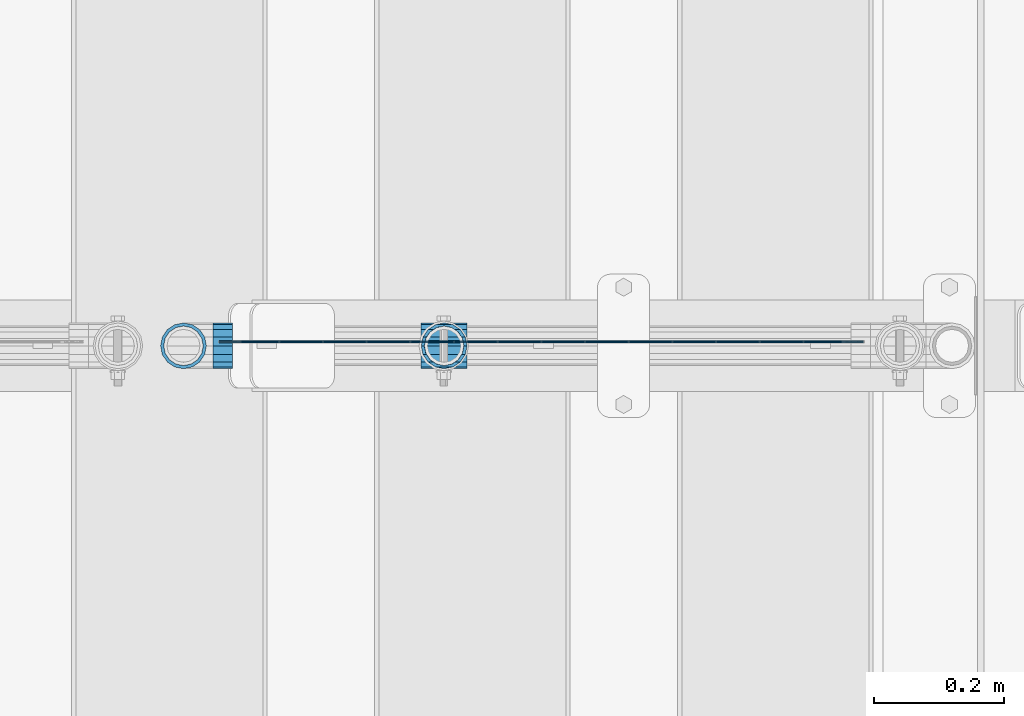
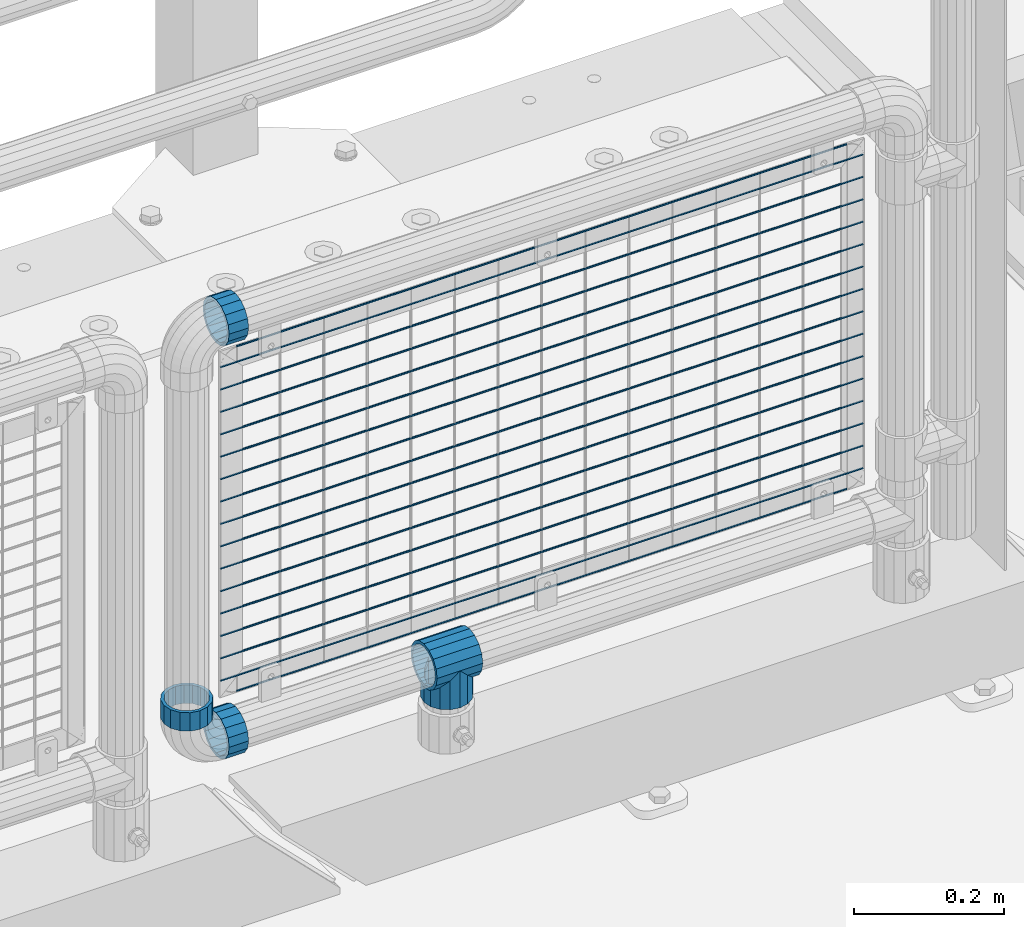
# One storey, part 135 of 208: 22 beams.
"""IFC2X3 building model written with IfcOpenShell, lengths in millimetres."""

import ifcopenshell
import ifcopenshell.guid

model = None  # the IFC model being written
_history = None  # IfcOwnerHistory: only IFC2X3 demands one
_inside = {}  # id of a spatial element -> (the spatial element, [elements in it])
_under = {}  # id of a project, library or spatial element -> (it, [spatial elements below it])
_declared = {}  # id of a project -> (the project, [libraries it declares])
_typed = {}  # id of a type object -> (the type object, [elements of that type])
_made_of = {}  # id of a material, layer set ... -> (it, [elements and type objects made of it])


def new_model(schema):
    """Start an empty IFC model of exactly this schema.

    Asked for "IFC4X3", IfcOpenShell would pick the latest addendum, in which some entities
    have other attributes; the version numbers below select the first issue.
    IFC2X3 requires an IfcOwnerHistory on every rooted entity: one is made here for all.
    """
    global model, _history
    if schema == "IFC4X3":
        model = ifcopenshell.file(schema_version=(4, 3, 0, 0))
    else:
        model = ifcopenshell.file(schema=schema)
    _inside.clear()
    _under.clear()
    _declared.clear()
    _typed.clear()
    _made_of.clear()
    _history = None
    if model.schema == "IFC2X3":
        org = make("IfcOrganization", Name="unknown")
        user = make(
            "IfcPersonAndOrganization",
            ThePerson=make("IfcPerson", FamilyName="unknown"),
            TheOrganization=org,
        )
        app = make(
            "IfcApplication",
            ApplicationDeveloper=org,
            Version="unknown",
            ApplicationFullName="unknown",
            ApplicationIdentifier="unknown",
        )
        _history = make(
            "IfcOwnerHistory",
            OwningUser=user,
            OwningApplication=app,
            ChangeAction="ADDED",
            CreationDate=0,
        )
    return model


def make(cls, **values):
    """One entity of the class cls with the attributes given. An attribute that is None is left unset."""
    return model.create_entity(
        cls, **{name: value for name, value in values.items() if value is not None}
    )


def rooted(cls, **values):
    """An entity with a GlobalId (a new one), such as an element, a storey or a relation."""
    return make(cls, GlobalId=ifcopenshell.guid.new(), OwnerHistory=_history, **values)


def si_unit(unit_type, name, prefix=None):
    """IfcSIUnit, for example si_unit("LENGTHUNIT", "METRE", prefix="MILLI")."""
    return make("IfcSIUnit", UnitType=unit_type, Prefix=prefix, Name=name)


def assignment(units):
    """IfcUnitAssignment: the units of a project."""
    return None if units is None else make("IfcUnitAssignment", Units=units)


def point(xyz):
    """IfcCartesianPoint."""
    return None if xyz is None else make("IfcCartesianPoint", Coordinates=xyz)


def direction(xyz):
    """IfcDirection."""
    return None if xyz is None else make("IfcDirection", DirectionRatios=xyz)


def frame(location, z_axis=None, x_axis=None):
    """IfcAxis2Placement3D, a coordinate frame: its origin and axes. An axis left out is left unset."""
    return make(
        "IfcAxis2Placement3D",
        Location=point(location),
        Axis=direction(z_axis),
        RefDirection=direction(x_axis),
    )


def origin_with_axes():
    """The frame at (0, 0, 0) with the z axis (0, 0, 1) and the x axis (1, 0, 0) written out."""
    return frame((0.0, 0.0, 0.0), z_axis=(0.0, 0.0, 1.0), x_axis=(1.0, 0.0, 0.0))


def place(relative_to, where):
    """IfcLocalPlacement: puts the frame where relative to a parent placement (None: the world)."""
    return make(
        "IfcLocalPlacement", PlacementRelTo=relative_to, RelativePlacement=where
    )


def context(
    kind, dimensions, precision=None, world=None, true_north=None, identifier=None
):
    """IfcGeometricRepresentationContext, for example the 3D "Model" context."""
    return make(
        "IfcGeometricRepresentationContext",
        ContextIdentifier=identifier,
        ContextType=kind,
        CoordinateSpaceDimension=dimensions,
        Precision=precision,
        WorldCoordinateSystem=world,
        TrueNorth=true_north,
    )


def subcontext(parent, identifier, kind, view, scale=None):
    """IfcGeometricRepresentationSubContext, for example "Body" below "Model"."""
    return make(
        "IfcGeometricRepresentationSubContext",
        ContextIdentifier=identifier,
        ContextType=kind,
        ParentContext=parent,
        TargetScale=scale,
        TargetView=view,
    )


def project(units=None, contexts=None):
    """IfcProject with its units and contexts."""
    return rooted(
        "IfcProject",
        Name="project",
        RepresentationContexts=contexts,
        UnitsInContext=assignment(units),
    )


def spatial(cls, under=None, at=None, **own):
    """A site, building, storey or space (cls), placed at a placement, below another one or the project."""
    s = rooted(cls, ObjectPlacement=at, **own)
    if under is not None:
        _under.setdefault(under.id(), (under, []))[1].append(s)
    return s


def faces_of(points, faces, orient=None, outer=None):
    """IfcFace entities. A face is a list of loops; a loop is a list of indices into points, from 0.

    orient and outer hold one flag for each loop. By default every Orientation is true, the
    first loop of a face is its IfcFaceOuterBound and the others are IfcFaceBound.
    """
    made = []
    for i, loops in enumerate(faces):
        bounds = []
        for j, loop in enumerate(loops):
            is_outer = j == 0 if outer is None else outer[i][j]
            bounds.append(
                make(
                    "IfcFaceOuterBound" if is_outer else "IfcFaceBound",
                    Bound=make("IfcPolyLoop", Polygon=[points[k] for k in loop]),
                    Orientation=True if orient is None else orient[i][j],
                )
            )
        made.append(make("IfcFace", Bounds=bounds))
    return made


def faceted_brep(points, faces, orient=None, outer=None, voids=None):
    """IfcFacetedBrep: a solid bounded by flat faces; with voids (closed shells), ...WithVoids."""
    shared = [point(p) for p in points]
    hull = make("IfcClosedShell", CfsFaces=faces_of(shared, faces, orient, outer))
    if voids is None:
        return make("IfcFacetedBrep", Outer=hull)
    return make(
        "IfcFacetedBrepWithVoids",
        Outer=hull,
        Voids=[
            make(cls, CfsFaces=faces_of(shared, fs, o, b)) for cls, fs, o, b in voids
        ],
    )


def shape(context_of_items, identifier, shape_type, items):
    """IfcShapeRepresentation: the items that make up one representation, for example the "Body"."""
    return make(
        "IfcShapeRepresentation",
        ContextOfItems=context_of_items,
        RepresentationIdentifier=identifier,
        RepresentationType=shape_type,
        Items=items,
    )


def material(Name=None, Category=None):
    """IfcMaterial."""
    return make("IfcMaterial", Name=Name, Category=Category)


def made_of(thing, what):
    """Note that an element or type object is made of a material, layer set ...; save() writes the relation."""
    if what is not None:
        _made_of.setdefault(what.id(), (what, []))[1].append(thing)
    return thing


def type_object(cls, material=None, **own):
    """A type object (cls), such as IfcWallType, which elements share."""
    return made_of(rooted(cls, **own), material)


def element(
    cls,
    number,
    at=None,
    inside=None,
    cuts=None,
    type_object=None,
    material=None,
    context=None,
    identifier="Body",
    shape_type=None,
    held_by="IfcProductDefinitionShape",
    body=None,
    shapes=None,
    **own,
):
    """One element of the class cls, such as IfcWall. Its Tag is "e" and its number.

    at: its placement. inside: the storey or other place that contains it. cuts: it is an
    opening in that element (IfcRelVoidsElement). A single representation is given by context,
    identifier, shape_type and body (its items); several are given by shapes. held_by: the class
    of the entity that holds the representations. save() writes the other relations.
    """
    e = rooted(cls, Tag="e%d" % number, ObjectPlacement=at, **own)
    if body is not None:
        shapes = [shape(context, identifier, shape_type, body)]
    if shapes is not None:
        e.Representation = make(held_by, Representations=shapes)
    if inside is not None:
        _inside.setdefault(inside.id(), (inside, []))[1].append(e)
    if cuts is not None:
        rooted(
            "IfcRelVoidsElement", RelatingBuildingElement=cuts, RelatedOpeningElement=e
        )
    if type_object is not None:
        _typed.setdefault(type_object.id(), (type_object, []))[1].append(e)
    return made_of(e, material)


def aggregate(whole, parts):
    """IfcRelAggregates: a whole, such as a stair, and the parts it consists of."""
    return rooted("IfcRelAggregates", RelatingObject=whole, RelatedObjects=parts)


def save(model, path):
    """Write the relations noted so far, then the file.

    IfcRelAggregates (storeys below a building ...), IfcRelContainedInSpatialStructure (elements
    in a storey), IfcRelDefinesByType, IfcRelAssociatesMaterial and IfcRelDeclares: one each for
    every whole, place, type object, material and project.
    """
    for whole, parts in _under.values():
        aggregate(whole, parts)
    for where, things in _inside.values():
        rooted(
            "IfcRelContainedInSpatialStructure",
            RelatedElements=things,
            RelatingStructure=where,
        )
    for kind, things in _typed.values():
        rooted("IfcRelDefinesByType", RelatedObjects=things, RelatingType=kind)
    for what, things in _made_of.values():
        rooted("IfcRelAssociatesMaterial", RelatedObjects=things, RelatingMaterial=what)
    for by, libraries in _declared.values():
        rooted("IfcRelDeclares", RelatingContext=by, RelatedDefinitions=libraries)
    model.write(path)


model = new_model("IFC2X3")

# Units and contexts
model_context = context("Model", 3, precision=1e-05, world=origin_with_axes())
body_context = subcontext(model_context, "Body", "Model", "MODEL_VIEW")
ifc_project = project(units=[si_unit("LENGTHUNIT", "METRE", prefix="MILLI"), si_unit("AREAUNIT", "SQUARE_METRE"), si_unit("VOLUMEUNIT", "CUBIC_METRE"), si_unit("MASSUNIT", "GRAM", prefix="KILO"), si_unit("TIMEUNIT", "SECOND"), si_unit("PLANEANGLEUNIT", "RADIAN"), si_unit("SOLIDANGLEUNIT", "STERADIAN"), si_unit("THERMODYNAMICTEMPERATUREUNIT", "DEGREE_CELSIUS"), si_unit("LUMINOUSINTENSITYUNIT", "LUMEN")], contexts=[model_context])

# Site, building, storey
site_placement = place(None, origin_with_axes())
site = spatial("IfcSite", under=ifc_project, at=site_placement, CompositionType="ELEMENT")
building_placement = place(site_placement, origin_with_axes())
building = spatial("IfcBuilding", under=site, at=building_placement, Name="Standard", CompositionType="ELEMENT")
storey_placement = place(building_placement, origin_with_axes())
storey = spatial("IfcBuildingStorey", under=building, at=storey_placement, Name="Undefined", CompositionType="ELEMENT", Elevation=0.0)

# Beams
ifc_material = material(Name="Misc_Undefined")
beam_type_1 = type_object("IfcBeamType", PredefinedType="NOTDEFINED")
beam_1_placement = place(storey_placement, frame((-26928.39, 4664.5, 298.169999999999), z_axis=(0.0, 1.0, 0.0), x_axis=(0.0, 0.0, -1.0)))
element("IfcBeam", 1, at=beam_1_placement, inside=storey, type_object=beam_type_1, material=ifc_material, context=body_context, shape_type="Brep", body=[
    faceted_brep([(0.0, 0.0, 35.1499999999996), (13.4513226476338, 13.4513226476329, 32.4743655677721), (13.4513226476338, -13.4513226476329, 32.4743655677721), (32.4743655677739, -32.4743655677717, -13.4513226476329), (32.4743655677739, -26.8123795176766, -13.4513226476329), (27.1226768591077, -21.4606908090117, -21.4606908090118), (24.8548033587067, -16.3810424080039, -24.8548033587067), (24.8548033587067, -24.8548033587072, -24.8548033587067), (13.4513226476338, -13.4513226476329, -32.4743655677721), (13.4513226476338, 13.4513226476329, -32.4743655677721), (0.0, 0.0, -35.1499999999996), (20.0882031229849, -11.6144421722805, -28.0397438117179), (16.6306603983685, 0.0, -30.3500000000004), (20.0882031229849, 11.6144421722805, -28.0397438117179), (24.8548033587067, 16.3810424080023, -24.8548033587067), (24.8548033587067, 24.8548033587072, -24.8548033587067), (32.4743655677739, 26.8123795176755, -13.4513226476329), (32.4743655677739, 32.4743655677717, -13.4513226476329), (27.1226768591077, 21.4606908090117, -21.4606908090118), (35.1500000000015, 30.35, 0.0), (35.1500000000015, 35.15, 0.0), (32.8397438117172, 28.0397438117175, -11.6144421722802), (32.8397438117172, 28.0397438117175, 11.6144421722802), (32.4743655677739, 26.812379517676, 13.4513226476329), (32.4743655677739, 32.4743655677717, 13.4513226476329), (27.1226768591005, 21.4606908090117, 21.4606908090118), (24.8548033587067, 16.3810424080032, 24.8548033587067), (24.8548033587067, 24.8548033587072, 24.8548033587067), (20.0882031229921, 11.6144421722805, 28.0397438117179), (16.6306603983685, 0.0, 30.3500000000004), (20.0882031229921, -11.6144421722805, 28.0397438117179), (24.8548033587067, -16.3810424080039, 24.8548033587067), (24.8548033587067, -24.8548033587072, 24.8548033587067), (27.1226768591005, -21.4606908090117, 21.4606908090118), (32.4743655677739, -26.8123795176755, 13.4513226476329), (32.4743655677739, -32.4743655677717, 13.4513226476329), (32.8397438117172, -28.0397438117175, 11.6144421722802), (35.1500000000015, -30.35, 0.0), (35.1500000000015, -35.1499999999996, 0.0), (32.8397438117172, -28.0397438117175, -11.6144421722802), (60.1500000000015, -24.8548033587072, -24.8548033587067), (60.1500000000015, -32.4743655677717, -13.4513226476329), (60.1500000000015, -13.4513226476329, -32.4743655677721), (60.1500000000015, 0.0, -35.1499999999996), (60.1500000000015, 13.4513226476329, -32.4743655677721), (60.1500000000015, 24.8548033587072, -24.8548033587067), (60.1500000000015, 32.4743655677717, -13.4513226476329), (60.1500000000015, 35.15, 0.0), (60.1500000000015, 32.4743655677717, 13.4513226476329), (60.1500000000015, 24.8548033587072, 24.8548033587067), (60.1500000000015, 13.4513226476329, 32.4743655677721), (60.1500000000015, 0.0, 35.1499999999996), (60.1500000000015, -13.4513226476329, 32.4743655677721), (60.1500000000015, -24.8548033587072, 24.8548033587067), (60.1500000000015, -32.4743655677717, 13.4513226476329), (60.1500000000015, -35.15, 0.0), (60.1500000000015, -21.4606908090117, 21.4606908090118), (60.1500000000015, -11.6144421722805, 28.0397438117179), (60.1500000000015, 0.0, 30.3500000000004), (60.1500000000015, 11.6144421722805, 28.0397438117179), (60.1500000000015, 21.4606908090117, 21.4606908090118), (60.1500000000015, 28.0397438117175, 11.6144421722802), (60.1500000000015, 30.35, 0.0), (60.1500000000015, 28.0397438117175, -11.6144421722802), (60.1500000000015, 21.4606908090117, -21.4606908090118), (60.1500000000015, 11.6144421722805, -28.0397438117179), (60.1500000000015, 0.0, -30.3500000000004), (60.1500000000015, -11.6144421722805, -28.0397438117179), (60.1500000000015, -21.4606908090117, -21.4606908090118), (60.1500000000015, -28.0397438117175, -11.6144421722802), (60.1500000000015, -30.35, 0.0), (60.1500000000015, -28.0397438117175, 11.6144421722802)], [[[0, 1, 2]], [[3, 4, 5, 6, 7]], [[8, 9, 10]], [[7, 6, 11, 12, 13, 14, 15, 9, 8]], [[16, 17, 15, 14, 18]], [[19, 20, 17, 16, 21]], [[22, 23, 24, 20, 19]], [[25, 26, 27, 24, 23]], [[2, 1, 27, 26, 28, 29, 30, 31, 32]], [[32, 31, 33, 34, 35]], [[35, 34, 36, 37, 38]], [[38, 37, 39, 4, 3]], [[40, 41, 3, 7]], [[42, 40, 7, 8]], [[43, 42, 8, 10]], [[44, 43, 10, 9]], [[45, 44, 9, 15]], [[46, 45, 15, 17]], [[47, 46, 17, 20]], [[48, 47, 20, 24]], [[49, 48, 24, 27]], [[50, 49, 27, 1]], [[51, 50, 1, 0]], [[52, 51, 0, 2]], [[53, 52, 2, 32]], [[54, 53, 32, 35]], [[55, 54, 35, 38]], [[41, 55, 38, 3]], [[40, 42, 43, 44, 45, 46, 47, 48, 49, 50, 51, 52, 53, 54, 55, 41], [56, 57, 58, 59, 60, 61, 62, 63, 64, 65, 66, 67, 68, 69, 70, 71]], [[71, 70, 37, 36]], [[33, 56, 71, 36, 34]], [[30, 57, 56, 33, 31]], [[58, 57, 30, 29]], [[59, 58, 29, 28]], [[60, 59, 28, 26, 25]], [[61, 60, 25, 23, 22]], [[62, 61, 22, 19]], [[63, 62, 19, 21]], [[18, 64, 63, 21, 16]], [[13, 65, 64, 18, 14]], [[66, 65, 13, 12]], [[67, 66, 12, 11]], [[68, 67, 11, 6, 5]], [[69, 68, 5, 4, 39]], [[70, 69, 39, 37]]]),
])
beam_2_placement = place(storey_placement, frame((-26963.54, 4664.5, 298.169999999999), z_axis=(0.0, 0.0, 1.0), x_axis=(1.0, 0.0, 0.0)))
element("IfcBeam", 2, at=beam_2_placement, inside=storey, type_object=beam_type_1, material=ifc_material, context=body_context, shape_type="Brep", body=[
    faceted_brep([(61.962379517675, -13.4513226476329, -32.4743655677739), (56.6106908090114, -21.4606908090118, -27.1226768591005), (56.6106908090114, -21.4606908090118, -21.4606908090136), (63.1897438117172, -11.6144421722802, -28.0397438117143), (63.1897438117172, -11.6144421722802, -32.8397438117245), (51.531042408003, -24.8548033587067, -24.8548033587067), (46.7644421722801, -28.0397438117179, -20.0882031229921), (46.7644421722801, -28.0397438117179, -11.6144421722784), (35.1499999999996, -30.3500000000004, -16.6306603983685), (35.1500000000015, -30.35, 0.0), (23.5355578277191, -28.0397438117179, -20.0882031229921), (23.5355578277191, -28.0397438117179, -11.6144421722784), (13.6893091909879, -21.4606908090118, -27.1226768591005), (13.6893091909879, -21.4606908090118, -21.4606908090136), (18.7689575919962, -24.8548033587067, -24.8548033587067), (7.11025618828205, -11.6144421722802, -32.8397438117245), (7.11025618828205, -11.6144421722802, -28.0397438117143), (8.33762048232325, -13.4513226476329, -32.4743655677739), (4.79999999999961, 0.0, -35.1500000000015), (4.79999999999961, 0.0, -30.3499999999985), (7.11025618828211, 11.6144421722802, -32.8397438117245), (7.11025618828211, 11.6144421722802, -28.0397438117143), (8.33762048232325, 13.4513226476329, -32.4743655677739), (13.6893091909879, 21.4606908090118, -27.1226768591077), (13.6893091909879, 21.4606908090118, -21.4606908090136), (18.7689575919962, 24.8548033587067, -24.8548033587067), (23.5355578277192, 28.0397438117179, -20.0882031229921), (23.5355578277192, 28.0397438117179, -11.6144421722784), (35.1499999999996, 30.3500000000004, -16.6306603983685), (35.1500000000015, 30.35, 0.0), (46.7644421722801, 28.0397438117179, -20.0882031229921), (46.7644421722801, 28.0397438117179, -11.6144421722784), (56.6106908090114, 21.4606908090118, -27.1226768591077), (56.6106908090114, 21.4606908090118, -21.4606908090136), (51.531042408003, 24.8548033587067, -24.8548033587067), (63.1897438117172, 11.6144421722802, -32.8397438117245), (63.1897438117172, 11.6144421722802, -28.0397438117143), (61.962379517676, 13.4513226476329, -32.4743655677739), (65.4999999999997, 0.0, -35.1500000000015), (65.4999999999997, 0.0, -30.3499999999985), (0.0, -21.4606908090118, -21.4606908090136), (0.0, -28.0397438117179, -11.6144421722784), (0.0, -11.6144421722802, -28.0397438117143), (0.0, 0.0, -30.3499999999985), (0.0, 11.6144421722802, -28.0397438117143), (0.0, 21.4606908090118, -21.4606908090136), (0.0, 28.0397438117179, -11.6144421722784), (0.0, 30.3500000000004, 0.0), (0.0, 32.4743655677721, -13.4513226476338), (0.0, 35.1499999999996, 0.0), (70.2999999999993, 35.1499999999996, 0.0), (70.2999999999993, 32.4743655677721, -13.4513226476338), (0.0, 32.4743655677721, 13.4513226476338), (70.2999999999993, 32.4743655677721, 13.4513226476338), (0.0, 24.8548033587067, 24.8548033587067), (70.2999999999993, 24.8548033587067, 24.8548033587067), (0.0, 13.4513226476329, 32.4743655677739), (70.2999999999993, 13.4513226476329, 32.4743655677739), (0.0, 0.0, 35.1499999999996), (70.2999999999993, 0.0, 35.1500000000015), (0.0, -13.4513226476329, 32.4743655677739), (70.2999999999993, -13.4513226476329, 32.4743655677739), (0.0, -24.8548033587067, 24.8548033587067), (70.2999999999993, -24.8548033587067, 24.8548033587067), (0.0, -32.4743655677721, 13.4513226476338), (70.2999999999993, -32.4743655677721, 13.4513226476338), (0.0, -35.1499999999996, 0.0), (70.2999999999993, -35.1499999999996, 0.0), (0.0, -32.4743655677721, -13.4513226476338), (70.2999999999993, -32.4743655677721, -13.4513226476338), (0.0, 24.8548033587067, -24.8548033587067), (0.0, 13.4513226476329, -32.4743655677739), (0.0, 0.0, -35.1499999999996), (0.0, -13.4513226476329, -32.4743655677739), (0.0, -24.8548033587067, -24.8548033587067), (0.0, 28.0397438117179, 11.6144421722784), (0.0, 21.4606908090118, 21.4606908090136), (0.0, 11.6144421722802, 28.0397438117143), (0.0, 0.0, 30.3499999999985), (0.0, -11.6144421722802, 28.0397438117143), (0.0, -21.4606908090118, 21.4606908090136), (0.0, -28.0397438117179, 11.6144421722784), (0.0, -30.3500000000004, 0.0), (70.2999999999993, -30.3500000000004, 0.0), (70.2999999999993, -28.0397438117179, -11.6144421722784), (70.2999999999993, -21.4606908090118, -21.4606908090136), (70.2999999999993, -11.6144421722802, -28.0397438117143), (70.2999999999993, 0.0, -30.3499999999985), (70.2999999999993, 21.4606908090118, -21.4606908090136), (70.2999999999993, 28.0397438117179, -11.6144421722784), (70.2999999999993, 11.6144421722802, -28.0397438117143), (70.2999999999993, 30.3500000000004, 0.0), (70.2999999999993, 28.0397438117179, 11.6144421722784), (70.2999999999993, 21.4606908090118, 21.4606908090136), (70.2999999999993, 11.6144421722802, 28.0397438117143), (70.2999999999993, 0.0, 30.3499999999985), (70.2999999999993, -11.6144421722802, 28.0397438117143), (70.2999999999993, -21.4606908090118, 21.4606908090136), (70.2999999999993, -28.0397438117179, 11.6144421722784), (70.2999999999993, -24.8548033587067, -24.8548033587067), (70.2999999999993, -13.4513226476329, -32.4743655677739), (70.2999999999993, 0.0, -35.1500000000015), (70.2999999999993, 13.4513226476329, -32.4743655677739), (70.2999999999993, 24.8548033587067, -24.8548033587067)], [[[0, 1, 2, 3, 4]], [[5, 6, 7, 2, 1]], [[8, 9, 7, 6]], [[10, 11, 9, 8]], [[12, 13, 11, 10, 14]], [[15, 16, 13, 12, 17]], [[18, 19, 16, 15]], [[20, 21, 19, 18]], [[22, 23, 24, 21, 20]], [[25, 26, 27, 24, 23]], [[28, 29, 27, 26]], [[30, 31, 29, 28]], [[32, 33, 31, 30, 34]], [[35, 36, 33, 32, 37]], [[38, 39, 36, 35]], [[4, 3, 39, 38]], [[40, 41, 11, 13]], [[42, 40, 13, 16]], [[43, 42, 16, 19]], [[44, 43, 19, 21]], [[45, 44, 21, 24]], [[46, 45, 24, 27]], [[47, 46, 27, 29]], [[48, 49, 50, 51]], [[49, 52, 53, 50]], [[52, 54, 55, 53]], [[54, 56, 57, 55]], [[56, 58, 59, 57]], [[58, 60, 61, 59]], [[60, 62, 63, 61]], [[62, 64, 65, 63]], [[64, 66, 67, 65]], [[66, 68, 69, 67]], [[64, 62, 60, 58, 56, 54, 52, 49, 48, 70, 71, 72, 73, 74, 68, 66], [41, 40, 42, 43, 44, 45, 46, 47, 75, 76, 77, 78, 79, 80, 81, 82]], [[41, 82, 9, 11]], [[83, 84, 7, 9]], [[84, 85, 2, 7]], [[85, 86, 3, 2]], [[86, 87, 39, 3]], [[88, 89, 31, 33]], [[90, 88, 33, 36]], [[87, 90, 36, 39]], [[89, 91, 29, 31]], [[75, 47, 29, 91, 92]], [[76, 75, 92, 93]], [[77, 76, 93, 94]], [[78, 77, 94, 95]], [[79, 78, 95, 96]], [[80, 79, 96, 97]], [[81, 80, 97, 98]], [[9, 82, 81, 98, 83]], [[99, 100, 101, 102, 103, 51, 50, 53, 55, 57, 59, 61, 63, 65, 67, 69], [97, 96, 95, 94, 93, 92, 91, 89, 88, 90, 87, 86, 85, 84, 83, 98]], [[37, 102, 101, 38, 35]], [[34, 103, 102, 37, 32]], [[28, 26, 25, 70, 48, 51, 103, 34, 30]], [[71, 70, 25, 23, 22]], [[72, 71, 22, 20, 18]], [[17, 73, 72, 18, 15]], [[14, 74, 73, 17, 12]], [[99, 69, 68, 74, 14, 10, 8, 6, 5]], [[100, 99, 5, 1, 0]], [[101, 100, 0, 4, 38]]]),
])
beam_3_placement = place(storey_placement, frame((-27283.39, 4664.5, 298.170000000001), z_axis=(0.0, 0.0, -1.0), x_axis=(1.0, 0.0, 0.0)))
element("IfcBeam", 3, at=beam_3_placement, inside=storey, type_object=beam_type_1, material=ifc_material, context=body_context, shape_type="Brep", body=[
    faceted_brep([(0.0, -30.3500000000004, 0.0), (0.0, -28.0397438117179, 11.6144421722784), (30.0, -28.0397438117179, 11.6144421722805), (30.0, -30.3500000000004, 0.0), (0.0, -21.4606908090118, 21.4606908090136), (30.0, -21.4606908090118, 21.4606908090117), (0.0, -11.6144421722802, 28.0397438117143), (30.0, -11.6144421722802, 28.0397438117175), (0.0, 0.0, 30.3499999999985), (30.0, 0.0, 30.35), (0.0, 11.6144421722802, 28.0397438117143), (30.0, 11.6144421722802, 28.0397438117175), (0.0, 21.4606908090118, 21.4606908090136), (30.0, 21.4606908090118, 21.4606908090117), (0.0, 28.0397438117179, 11.6144421722784), (30.0, 28.0397438117179, 11.6144421722805), (0.0, 30.3500000000004, 0.0), (30.0, 30.3500000000004, 0.0), (0.0, 28.0397438117179, -11.6144421722784), (30.0, 28.0397438117179, -11.6144421722805), (0.0, 21.4606908090118, -21.4606908090136), (30.0, 21.4606908090118, -21.4606908090117), (0.0, 11.6144421722802, -28.0397438117143), (30.0, 11.6144421722802, -28.0397438117175), (0.0, 0.0, -30.3499999999985), (30.0, 0.0, -30.35), (0.0, -11.6144421722802, -28.0397438117143), (30.0, -11.6144421722802, -28.0397438117175), (0.0, -21.4606908090118, -21.4606908090136), (30.0, -21.4606908090118, -21.4606908090117), (0.0, -28.0397438117179, -11.6144421722784), (30.0, -28.0397438117179, -11.6144421722805), (0.0, -35.1499999999996, 0.0), (0.0, -32.4743655677721, -13.4513226476338), (30.0, -32.4743655677721, -13.4513226476329), (30.0, -35.1499999999996, 0.0), (0.0, -24.8548033587067, -24.8548033587067), (30.0, -24.8548033587067, -24.8548033587072), (0.0, -13.4513226476329, -32.4743655677739), (30.0, -13.4513226476329, -32.4743655677717), (0.0, 0.0, -35.1499999999996), (30.0, 0.0, -35.15), (0.0, 13.4513226476329, -32.4743655677739), (30.0, 13.4513226476329, -32.4743655677717), (0.0, 24.8548033587067, -24.8548033587067), (30.0, 24.8548033587067, -24.8548033587072), (0.0, 32.4743655677721, -13.4513226476338), (30.0, 32.4743655677721, -13.4513226476329), (0.0, 35.1499999999996, 0.0), (30.0, 35.1499999999996, 0.0), (0.0, 32.4743655677721, 13.4513226476338), (30.0, 32.4743655677721, 13.4513226476329), (0.0, 24.8548033587067, 24.8548033587067), (30.0, 24.8548033587067, 24.8548033587072), (0.0, 13.4513226476329, 32.4743655677739), (30.0, 13.4513226476329, 32.4743655677717), (0.0, 0.0, 35.1499999999996), (30.0, 0.0, 35.15), (0.0, -13.4513226476329, 32.4743655677739), (30.0, -13.4513226476329, 32.4743655677717), (0.0, -24.8548033587067, 24.8548033587067), (30.0, -24.8548033587067, 24.8548033587072), (0.0, -32.4743655677721, 13.4513226476338), (30.0, -32.4743655677721, 13.4513226476329)], [[[0, 1, 2, 3]], [[1, 4, 5, 2]], [[4, 6, 7, 5]], [[6, 8, 9, 7]], [[8, 10, 11, 9]], [[10, 12, 13, 11]], [[12, 14, 15, 13]], [[14, 16, 17, 15]], [[16, 18, 19, 17]], [[18, 20, 21, 19]], [[20, 22, 23, 21]], [[22, 24, 25, 23]], [[24, 26, 27, 25]], [[26, 28, 29, 27]], [[28, 30, 31, 29]], [[30, 0, 3, 31]], [[32, 33, 34, 35]], [[33, 36, 37, 34]], [[36, 38, 39, 37]], [[38, 40, 41, 39]], [[40, 42, 43, 41]], [[42, 44, 45, 43]], [[44, 46, 47, 45]], [[46, 48, 49, 47]], [[48, 50, 51, 49]], [[50, 52, 53, 51]], [[52, 54, 55, 53]], [[54, 56, 57, 55]], [[56, 58, 59, 57]], [[58, 60, 61, 59]], [[60, 62, 63, 61]], [[62, 32, 35, 63]], [[37, 39, 41, 43, 45, 47, 49, 51, 53, 55, 57, 59, 61, 63, 35, 34], [5, 7, 9, 11, 13, 15, 17, 19, 21, 23, 25, 27, 29, 31, 3, 2]], [[62, 60, 58, 56, 54, 52, 50, 48, 46, 44, 42, 40, 38, 36, 33, 32], [30, 28, 26, 24, 22, 20, 18, 16, 14, 12, 10, 8, 6, 4, 1, 0]]]),
])
beam_4_placement = place(storey_placement, frame((-27328.39, 4664.5, 373.170000000002), z_axis=(-1.0, 0.0, 0.0), x_axis=(0.0, 0.0, -1.0)))
element("IfcBeam", 4, at=beam_4_placement, inside=storey, type_object=beam_type_1, material=ifc_material, context=body_context, shape_type="Brep", body=[
    faceted_brep([(0.0, -30.3500000000004, 0.0), (0.0, -28.0397438117179, 11.6144421722784), (30.0, -28.0397438117179, 11.6144421722805), (30.0, -30.3500000000004, 0.0), (0.0, -21.4606908090118, 21.4606908090136), (30.0, -21.4606908090118, 21.4606908090117), (0.0, -11.6144421722802, 28.0397438117143), (30.0, -11.6144421722802, 28.0397438117175), (0.0, 0.0, 30.3499999999985), (30.0, 0.0, 30.35), (0.0, 11.6144421722802, 28.0397438117143), (30.0, 11.6144421722802, 28.0397438117175), (0.0, 21.4606908090118, 21.4606908090136), (30.0, 21.4606908090118, 21.4606908090117), (0.0, 28.0397438117179, 11.6144421722784), (30.0, 28.0397438117179, 11.6144421722805), (0.0, 30.3500000000004, 0.0), (30.0, 30.3500000000004, 0.0), (0.0, 28.0397438117179, -11.6144421722784), (30.0, 28.0397438117179, -11.6144421722805), (0.0, 21.4606908090118, -21.4606908090136), (30.0, 21.4606908090118, -21.4606908090117), (0.0, 11.6144421722802, -28.0397438117143), (30.0, 11.6144421722802, -28.0397438117175), (0.0, 0.0, -30.3499999999985), (30.0, 0.0, -30.35), (0.0, -11.6144421722802, -28.0397438117143), (30.0, -11.6144421722802, -28.0397438117175), (0.0, -21.4606908090118, -21.4606908090136), (30.0, -21.4606908090118, -21.4606908090117), (0.0, -28.0397438117179, -11.6144421722784), (30.0, -28.0397438117179, -11.6144421722805), (0.0, -35.1499999999996, 0.0), (0.0, -32.4743655677721, -13.4513226476338), (30.0, -32.4743655677721, -13.4513226476329), (30.0, -35.1499999999996, 0.0), (0.0, -24.8548033587067, -24.8548033587067), (30.0, -24.8548033587067, -24.8548033587072), (0.0, -13.4513226476329, -32.4743655677739), (30.0, -13.4513226476329, -32.4743655677717), (0.0, 0.0, -35.1499999999996), (30.0, 0.0, -35.15), (0.0, 13.4513226476329, -32.4743655677739), (30.0, 13.4513226476329, -32.4743655677717), (0.0, 24.8548033587067, -24.8548033587067), (30.0, 24.8548033587067, -24.8548033587072), (0.0, 32.4743655677721, -13.4513226476338), (30.0, 32.4743655677721, -13.4513226476329), (0.0, 35.1499999999996, 0.0), (30.0, 35.1499999999996, 0.0), (0.0, 32.4743655677721, 13.4513226476338), (30.0, 32.4743655677721, 13.4513226476329), (0.0, 24.8548033587067, 24.8548033587067), (30.0, 24.8548033587067, 24.8548033587072), (0.0, 13.4513226476329, 32.4743655677739), (30.0, 13.4513226476329, 32.4743655677717), (0.0, 0.0, 35.1499999999996), (30.0, 0.0, 35.15), (0.0, -13.4513226476329, 32.4743655677739), (30.0, -13.4513226476329, 32.4743655677717), (0.0, -24.8548033587067, 24.8548033587067), (30.0, -24.8548033587067, 24.8548033587072), (0.0, -32.4743655677721, 13.4513226476338), (30.0, -32.4743655677721, 13.4513226476329)], [[[0, 1, 2, 3]], [[1, 4, 5, 2]], [[4, 6, 7, 5]], [[6, 8, 9, 7]], [[8, 10, 11, 9]], [[10, 12, 13, 11]], [[12, 14, 15, 13]], [[14, 16, 17, 15]], [[16, 18, 19, 17]], [[18, 20, 21, 19]], [[20, 22, 23, 21]], [[22, 24, 25, 23]], [[24, 26, 27, 25]], [[26, 28, 29, 27]], [[28, 30, 31, 29]], [[30, 0, 3, 31]], [[32, 33, 34, 35]], [[33, 36, 37, 34]], [[36, 38, 39, 37]], [[38, 40, 41, 39]], [[40, 42, 43, 41]], [[42, 44, 45, 43]], [[44, 46, 47, 45]], [[46, 48, 49, 47]], [[48, 50, 51, 49]], [[50, 52, 53, 51]], [[52, 54, 55, 53]], [[54, 56, 57, 55]], [[56, 58, 59, 57]], [[58, 60, 61, 59]], [[60, 62, 63, 61]], [[62, 32, 35, 63]], [[37, 39, 41, 43, 45, 47, 49, 51, 53, 55, 57, 59, 61, 63, 35, 34], [5, 7, 9, 11, 13, 15, 17, 19, 21, 23, 25, 27, 29, 31, 3, 2]], [[62, 60, 58, 56, 54, 52, 50, 48, 46, 44, 42, 40, 38, 36, 33, 32], [30, 28, 26, 24, 22, 20, 18, 16, 14, 12, 10, 8, 6, 4, 1, 0]]]),
])
beam_5_placement = place(storey_placement, frame((-27283.39, 4664.5, 969.849999999999), z_axis=(0.0, 0.0, 1.0), x_axis=(1.0, 0.0, 0.0)))
element("IfcBeam", 5, at=beam_5_placement, inside=storey, type_object=beam_type_1, material=ifc_material, context=body_context, shape_type="Brep", body=[
    faceted_brep([(0.0, -30.3500000000004, 0.0), (0.0, -28.0397438117179, 11.6144421722784), (30.0, -28.0397438117179, 11.6144421722805), (30.0, -30.3500000000004, 0.0), (0.0, -21.4606908090118, 21.4606908090136), (30.0, -21.4606908090118, 21.4606908090117), (0.0, -11.6144421722802, 28.0397438117143), (30.0, -11.6144421722802, 28.0397438117175), (0.0, 0.0, 30.3499999999985), (30.0, 0.0, 30.35), (0.0, 11.6144421722802, 28.0397438117143), (30.0, 11.6144421722802, 28.0397438117175), (0.0, 21.4606908090118, 21.4606908090136), (30.0, 21.4606908090118, 21.4606908090117), (0.0, 28.0397438117179, 11.6144421722784), (30.0, 28.0397438117179, 11.6144421722805), (0.0, 30.3500000000004, 0.0), (30.0, 30.3500000000004, 0.0), (0.0, 28.0397438117179, -11.6144421722784), (30.0, 28.0397438117179, -11.6144421722805), (0.0, 21.4606908090118, -21.4606908090136), (30.0, 21.4606908090118, -21.4606908090117), (0.0, 11.6144421722802, -28.0397438117143), (30.0, 11.6144421722802, -28.0397438117175), (0.0, 0.0, -30.3499999999985), (30.0, 0.0, -30.35), (0.0, -11.6144421722802, -28.0397438117143), (30.0, -11.6144421722802, -28.0397438117175), (0.0, -21.4606908090118, -21.4606908090136), (30.0, -21.4606908090118, -21.4606908090117), (0.0, -28.0397438117179, -11.6144421722784), (30.0, -28.0397438117179, -11.6144421722805), (0.0, -35.1499999999996, 0.0), (0.0, -32.4743655677721, -13.4513226476338), (30.0, -32.4743655677721, -13.4513226476329), (30.0, -35.1499999999996, 0.0), (0.0, -24.8548033587067, -24.8548033587067), (30.0, -24.8548033587067, -24.8548033587072), (0.0, -13.4513226476329, -32.4743655677739), (30.0, -13.4513226476329, -32.4743655677717), (0.0, 0.0, -35.1499999999996), (30.0, 0.0, -35.15), (0.0, 13.4513226476329, -32.4743655677739), (30.0, 13.4513226476329, -32.4743655677717), (0.0, 24.8548033587067, -24.8548033587067), (30.0, 24.8548033587067, -24.8548033587072), (0.0, 32.4743655677721, -13.4513226476338), (30.0, 32.4743655677721, -13.4513226476329), (0.0, 35.1499999999996, 0.0), (30.0, 35.1499999999996, 0.0), (0.0, 32.4743655677721, 13.4513226476338), (30.0, 32.4743655677721, 13.4513226476329), (0.0, 24.8548033587067, 24.8548033587067), (30.0, 24.8548033587067, 24.8548033587072), (0.0, 13.4513226476329, 32.4743655677739), (30.0, 13.4513226476329, 32.4743655677717), (0.0, 0.0, 35.1499999999996), (30.0, 0.0, 35.15), (0.0, -13.4513226476329, 32.4743655677739), (30.0, -13.4513226476329, 32.4743655677717), (0.0, -24.8548033587067, 24.8548033587067), (30.0, -24.8548033587067, 24.8548033587072), (0.0, -32.4743655677721, 13.4513226476338), (30.0, -32.4743655677721, 13.4513226476329)], [[[0, 1, 2, 3]], [[1, 4, 5, 2]], [[4, 6, 7, 5]], [[6, 8, 9, 7]], [[8, 10, 11, 9]], [[10, 12, 13, 11]], [[12, 14, 15, 13]], [[14, 16, 17, 15]], [[16, 18, 19, 17]], [[18, 20, 21, 19]], [[20, 22, 23, 21]], [[22, 24, 25, 23]], [[24, 26, 27, 25]], [[26, 28, 29, 27]], [[28, 30, 31, 29]], [[30, 0, 3, 31]], [[32, 33, 34, 35]], [[33, 36, 37, 34]], [[36, 38, 39, 37]], [[38, 40, 41, 39]], [[40, 42, 43, 41]], [[42, 44, 45, 43]], [[44, 46, 47, 45]], [[46, 48, 49, 47]], [[48, 50, 51, 49]], [[50, 52, 53, 51]], [[52, 54, 55, 53]], [[54, 56, 57, 55]], [[56, 58, 59, 57]], [[58, 60, 61, 59]], [[60, 62, 63, 61]], [[62, 32, 35, 63]], [[37, 39, 41, 43, 45, 47, 49, 51, 53, 55, 57, 59, 61, 63, 35, 34], [5, 7, 9, 11, 13, 15, 17, 19, 21, 23, 25, 27, 29, 31, 3, 2]], [[62, 60, 58, 56, 54, 52, 50, 48, 46, 44, 42, 40, 38, 36, 33, 32], [30, 28, 26, 24, 22, 20, 18, 16, 14, 12, 10, 8, 6, 4, 1, 0]]]),
])
beam_type_2 = type_object("IfcBeamType", Name="D3", PredefinedType="NOTDEFINED")
for number, where, z_axis, x_axis in (
    (6, (-27273.39, 4670.49998833461, 633.023), (0.0, 0.0, 1.0), (1.0, 0.0, 0.0)),
    (7, (-27273.39, 4670.49998833846, 815.168), (0.0, 0.0, 1.0), (1.0, 0.0, 0.0)),
    (8, (-27273.39, 4670.49998833538, 669.452), (0.0, 0.0, 1.0), (1.0, 0.0, 0.0)),
    (9, (-27273.39, 4670.49998833384, 596.594000000001), (0.0, 0.0, 1.0), (1.0, 0.0, 0.0)),
    (10, (-27273.39, 4670.49998833307, 560.165), (0.0, 0.0, 1.0), (1.0, 0.0, 0.0)),
    (11, (-27273.39, 4670.49998833769, 778.739), (0.0, 0.0, 1.0), (1.0, 0.0, 0.0)),
    (12, (-27273.39, 4670.4999883323, 523.736), (0.0, 0.0, 1.0), (1.0, 0.0, 0.0)),
    (13, (-27273.39, 4670.49998833923, 851.597), (0.0, 0.0, 1.0), (1.0, 0.0, 0.0)),
    (14, (-27273.39, 4670.49998833153, 487.307), (0.0, 0.0, 1.0), (1.0, 0.0, 0.0)),
    (15, (-27273.39, 4670.49998833615, 705.881), (0.0, 0.0, 1.0), (1.0, 0.0, 0.0)),
    (16, (-27273.39, 4670.49998833076, 450.878), (0.0, 0.0, 1.0), (1.0, 0.0, 0.0)),
    (17, (-27273.39, 4670.49998834, 888.026), (0.0, 0.0, 1.0), (1.0, 0.0, 0.0)),
    (18, (-27273.39, 4670.49998833692, 742.31), (0.0, 0.0, 1.0), (1.0, 0.0, 0.0)),
    (19, (-27273.39, 4670.49998832999, 414.449), (0.0, 0.0, 1.0), (1.0, 0.0, 0.0)),
):
    element("IfcBeam", number, at=place(storey_placement, frame(where, z_axis=z_axis, x_axis=x_axis)), inside=storey, type_object=beam_type_2, material=ifc_material, ObjectType="D3", context=body_context, shape_type="Brep", body=[
        faceted_brep([(0.0, -1.49999999999909, 3.63797880709171e-12), (-7.27595761418343e-12, -0.749999999999091, -1.29903810567669), (988.390000000236, -0.749999999999091, -1.29903810567669), (988.390000000236, -1.49999999999909, 0.0), (-3.63797880709171e-12, 0.750000000000909, -1.29903810567669), (988.390000000236, 0.750000000000909, -1.29903810567669), (0.0, 1.50000000000182, 3.63797880709171e-12), (988.390000000236, 1.50000000000091, 0.0), (-3.63797880709171e-12, 0.750000000000909, 1.29903810567669), (988.390000000236, 0.750000000000909, 1.29903810567669), (-7.27595761418343e-12, -0.749999999999091, 1.29903810567669), (988.390000000236, -0.749999999999091, 1.29903810567669)], [[[0, 1, 2, 3]], [[1, 4, 5, 2]], [[4, 6, 7, 5]], [[6, 8, 9, 7]], [[8, 10, 11, 9]], [[10, 0, 3, 11]], [[5, 7, 9, 11, 3, 2]], [[10, 8, 6, 4, 1, 0]]]),
    ])
beam_6_placement = place(storey_placement, frame((-27248.39, 4670.49998302432, 353.02), z_axis=(0.0, 0.0, 1.0), x_axis=(1.0, 0.0, 0.0)))
element("IfcBeam", 20, at=beam_6_placement, inside=storey, type_object=beam_type_2, material=ifc_material, ObjectType="D3", context=body_context, shape_type="Brep", body=[
    faceted_brep([(0.0, -1.49999999999909, 3.63797880709171e-12), (-7.27595761418343e-12, -0.749999999999091, -1.29903810567669), (938.39000000009, -0.749999999999091, -1.29903810567669), (938.390000000094, -1.49999999999909, 0.0), (-3.63797880709171e-12, 0.750000000000909, -1.29903810567669), (938.390000000094, 0.750000000000909, -1.29903810567663), (0.0, 1.50000000000182, 3.63797880709171e-12), (938.39000000009, 1.50000000000091, 0.0), (-3.63797880709171e-12, 0.750000000000909, 1.29903810567669), (938.390000000094, 0.750000000000909, 1.29903810567669), (-7.27595761418343e-12, -0.749999999999091, 1.29903810567669), (938.39000000009, -0.749999999999091, 1.29903810567669)], [[[0, 1, 2, 3]], [[1, 4, 5, 2]], [[4, 6, 7, 5]], [[6, 8, 9, 7]], [[8, 10, 11, 9]], [[10, 0, 3, 11]], [[5, 7, 9, 11, 3, 2]], [[10, 8, 6, 4, 1, 0]]]),
])
beam_7_placement = place(storey_placement, frame((-27273.39, 4670.49998832922, 378.02), z_axis=(0.0, 0.0, 1.0), x_axis=(1.0, 0.0, 0.0)))
element("IfcBeam", 21, at=beam_7_placement, inside=storey, type_object=beam_type_2, material=ifc_material, ObjectType="D3", context=body_context, shape_type="Brep", body=[
    faceted_brep([(0.0, -1.49999999999909, 3.63797880709171e-12), (-7.27595761418343e-12, -0.749999999999091, -1.29903810567669), (988.390000000236, -0.749999999999091, -1.29903810567669), (988.390000000236, -1.49999999999909, 0.0), (-3.63797880709171e-12, 0.750000000000909, -1.29903810567669), (988.390000000236, 0.750000000000909, -1.29903810567669), (0.0, 1.50000000000182, 3.63797880709171e-12), (988.390000000236, 1.50000000000091, 0.0), (-3.63797880709171e-12, 0.750000000000909, 1.29903810567669), (988.390000000236, 0.750000000000909, 1.29903810567669), (-7.27595761418343e-12, -0.749999999999091, 1.29903810567669), (988.390000000236, -0.749999999999091, 1.29903810567669)], [[[0, 1, 2, 3]], [[1, 4, 5, 2]], [[4, 6, 7, 5]], [[6, 8, 9, 7]], [[8, 10, 11, 9]], [[10, 0, 3, 11]], [[5, 7, 9, 11, 3, 2]], [[10, 8, 6, 4, 1, 0]]]),
])
beam_8_placement = place(storey_placement, frame((-27248.39, 4670.49998304, 913.02), z_axis=(0.0, 0.0, 1.0), x_axis=(1.0, 0.0, 0.0)))
element("IfcBeam", 22, at=beam_8_placement, inside=storey, type_object=beam_type_2, material=ifc_material, ObjectType="D3", context=body_context, shape_type="Brep", body=[
    faceted_brep([(0.0, -1.49999999999909, 3.63797880709171e-12), (-7.27595761418343e-12, -0.749999999999091, -1.29903810567669), (938.39000000009, -0.749999999999091, -1.29903810567669), (938.390000000094, -1.49999999999909, 0.0), (-3.63797880709171e-12, 0.750000000000909, -1.29903810567669), (938.390000000094, 0.750000000000909, -1.29903810567663), (0.0, 1.50000000000182, 3.63797880709171e-12), (938.39000000009, 1.50000000000091, 0.0), (-3.63797880709171e-12, 0.750000000000909, 1.29903810567669), (938.390000000094, 0.750000000000909, 1.29903810567669), (-7.27595761418343e-12, -0.749999999999091, 1.29903810567669), (938.39000000009, -0.749999999999091, 1.29903810567669)], [[[0, 1, 2, 3]], [[1, 4, 5, 2]], [[4, 6, 7, 5]], [[6, 8, 9, 7]], [[8, 10, 11, 9]], [[10, 0, 3, 11]], [[5, 7, 9, 11, 3, 2]], [[10, 8, 6, 4, 1, 0]]]),
])

save(model, "model.ifc")
